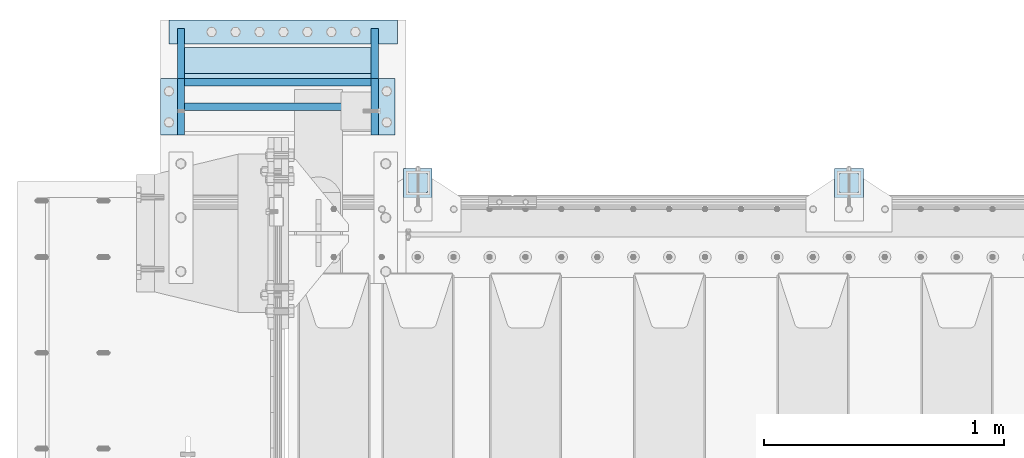
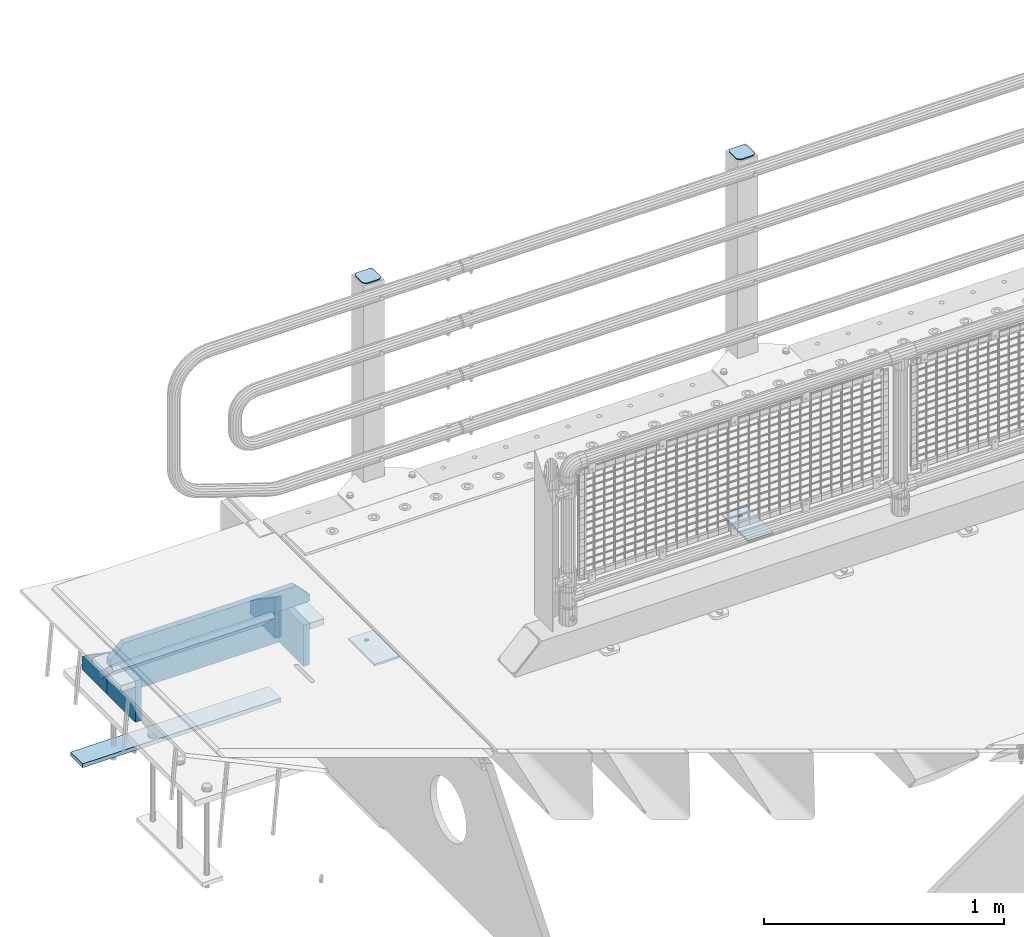
# One storey, part 214 of 247: 14 plates.
"""IFC2X3 building model written with IfcOpenShell, lengths in millimetres."""

from ifc_helpers import new_model, si_unit, frame, origin_with_axes, place, context, subcontext, project, spatial, faceted_brep, material, type_object, element, save


model = new_model("IFC2X3")

# Units and contexts
model_context = context("Model", 3, precision=1e-05, world=origin_with_axes())
body_context = subcontext(model_context, "Body", "Model", "MODEL_VIEW")
ifc_project = project(units=[si_unit("LENGTHUNIT", "METRE", prefix="MILLI"), si_unit("AREAUNIT", "SQUARE_METRE"), si_unit("VOLUMEUNIT", "CUBIC_METRE"), si_unit("MASSUNIT", "GRAM", prefix="KILO"), si_unit("TIMEUNIT", "SECOND"), si_unit("PLANEANGLEUNIT", "RADIAN"), si_unit("SOLIDANGLEUNIT", "STERADIAN"), si_unit("THERMODYNAMICTEMPERATUREUNIT", "DEGREE_CELSIUS"), si_unit("LUMINOUSINTENSITYUNIT", "LUMEN")], contexts=[model_context])

# Site, building, storey
site_placement = place(None, origin_with_axes())
site = spatial("IfcSite", under=ifc_project, at=site_placement, CompositionType="ELEMENT")
building_placement = place(site_placement, origin_with_axes())
building = spatial("IfcBuilding", under=site, at=building_placement, Name="Standard", CompositionType="ELEMENT")
storey_placement = place(building_placement, origin_with_axes())
storey = spatial("IfcBuildingStorey", under=building, at=storey_placement, Name="Undefined", CompositionType="ELEMENT", Elevation=0.0)

# Plates
ifc_material_1 = material(Name="STEEL/S355N")
plate_type_1 = type_object("IfcPlateType", PredefinedType="NOTDEFINED")
plate_1_placement = place(storey_placement, frame((354.999999574466, 9765.35713634785, -1017.14966545659), z_axis=(-1.0, 0.0, 0.0), x_axis=(9.99999918650255e-10, -0.723355636225728, 0.690475650215467)))
element("IfcPlate", 1, at=plate_1_placement, inside=storey, type_object=plate_type_1, material=ifc_material_1, context=body_context, shape_type="Brep", body=[
    faceted_brep([(0.0, -15.0, 0.0), (2.15506588574499e-07, -15.0, 779.0), (2.15505679079797e-07, 15.0000000000009, 779.0), (0.0, 15.0, 0.0), (152.069061494803, -14.9999999999991, 779.0), (152.069061494803, 15.0000000000009, 779.0), (152.069061279297, -14.9999999999991, 0.0), (152.069061279298, 15.0000000000009, 5.6843418860808e-14)], [[[0, 1, 2, 3]], [[1, 4, 5, 2]], [[4, 6, 7, 5]], [[6, 0, 3, 7]], [[5, 7, 3, 2]], [[6, 4, 1, 0]]]),
])
plate_type_2 = type_object("IfcPlateType", PredefinedType="NOTDEFINED")
plate_2_placement = place(storey_placement, frame((-489.000000550232, 9889.99999928438, -1468.0), z_axis=(0.0, -0.999999999999548, -9.5100000000016e-07), x_axis=(1.0, 0.0, 0.0)))
element("IfcPlate", 2, at=plate_2_placement, inside=storey, type_object=plate_type_2, material=ifc_material_1, context=body_context, shape_type="Brep", body=[
    faceted_brep([(-5.6843418860808e-14, -9.99999999999989, 3.5527136788005e-15), (0.0, -10.0, 100.0), (0.0, 10.0, 100.0), (-5.6843418860808e-14, 10.0000000000001, 3.5527136788005e-15), (955.0, -10.0, 100.0), (955.0, 10.0, 100.0), (955.0, -10.0, 0.0), (955.0, 10.0, 0.0)], [[[0, 1, 2, 3]], [[1, 4, 5, 2]], [[4, 6, 7, 5]], [[6, 0, 3, 7]], [[5, 7, 3, 2]], [[6, 4, 1, 0]]]),
])
plate_type_3 = type_object("IfcPlateType", PredefinedType="NOTDEFINED")
for number, where, z_axis, x_axis in (
    (3, (369.999999484786, 9855.00000160961, -1028.0), (0.0, 0.0, 1.0), (0.0, -0.999999999999548, -9.5100000000016e-07)),
    (4, (-439.000000515218, 9855.00000080062, -1028.0), (0.0, 0.0, 1.0), (0.0, -0.999999999999548, -9.5100000000016e-07)),
):
    element("IfcPlate", number, at=place(storey_placement, frame(where, z_axis=z_axis, x_axis=x_axis)), inside=storey, type_object=plate_type_3, material=ifc_material_1, context=body_context, shape_type="Brep", body=[
        faceted_brep([(0.0, -15.0, 0.0), (-1.81898940354586e-12, -15.0, 66.0), (0.0, 15.0, 66.0), (0.0, 15.0, 0.0), (209.999999999998, -15.0, 210.0), (210.0, 15.0, 210.0), (209.999999999998, -15.0, 0.0), (210.0, 15.0, 0.0)], [[[0, 1, 2, 3]], [[1, 4, 5, 2]], [[4, 6, 7, 5]], [[6, 0, 3, 7]], [[5, 7, 3, 2]], [[6, 4, 1, 0]]]),
    ])
plate_3_placement = place(storey_placement, frame((369.999999929983, 9410.00000160961, -818.000000000005), z_axis=(0.0, 0.0, -1.0), x_axis=(0.0, 1.0, 0.0)))
element("IfcPlate", 5, at=plate_3_placement, inside=storey, type_object=plate_type_3, material=ifc_material_1, context=body_context, shape_type="Brep", body=[
    faceted_brep([(0.0, -15.0, 0.0), (1.81898940354586e-12, -15.0, 210.0), (0.0, 15.0, 210.0), (0.0, 15.0, 0.0), (235.000000000002, -15.0, 210.0), (235.0, 15.0, 210.0), (235.0, -15.0, 0.0), (235.0, 15.0, 0.0)], [[[0, 1, 2, 3]], [[1, 4, 5, 2]], [[4, 6, 7, 5]], [[6, 0, 3, 7]], [[5, 7, 3, 2]], [[6, 4, 1, 0]]]),
])
plate_4_placement = place(storey_placement, frame((-424.000000290114, 9630.00000081562, -1028.0), z_axis=(1.0, 0.0, 0.0), x_axis=(0.0, 0.0, 1.0)))
element("IfcPlate", 6, at=plate_4_placement, inside=storey, type_object=plate_type_3, material=ifc_material_1, context=body_context, shape_type="Brep", body=[
    faceted_brep([(0.0, -15.0, 0.0), (2.15506588574499e-07, -15.0, 779.0), (2.15505679079797e-07, 15.0000000000009, 779.0), (0.0, 15.0, 0.0), (210.0, -15.0, 779.0), (210.0, 15.0, 779.0), (209.999999999998, -15.0, 0.0), (210.0, 15.0, 0.0)], [[[0, 1, 2, 3]], [[1, 4, 5, 2]], [[4, 6, 7, 5]], [[6, 0, 3, 7]], [[5, 7, 3, 2]], [[6, 4, 1, 0]]]),
])
plate_5_placement = place(storey_placement, frame((-439.000000070017, 9410.00000080062, -818.000000000004), z_axis=(0.0, 0.0, -1.0), x_axis=(0.0, 1.0, 0.0)))
element("IfcPlate", 7, at=plate_5_placement, inside=storey, type_object=plate_type_3, material=ifc_material_1, context=body_context, shape_type="Brep", body=[
    faceted_brep([(0.0, -15.0, 0.0), (1.81898940354586e-12, -15.0, 210.0), (0.0, 15.0, 210.0), (0.0, 15.0, 0.0), (235.000000000002, -15.0, 210.0), (235.0, 15.0, 210.0), (235.0, -15.0, 0.0), (235.0, 15.0, 0.0)], [[[0, 1, 2, 3]], [[1, 4, 5, 2]], [[4, 6, 7, 5]], [[6, 0, 3, 7]], [[5, 7, 3, 2]], [[6, 4, 1, 0]]]),
])
plate_type_4 = type_object("IfcPlateType", PredefinedType="NOTDEFINED")
plate_6_placement = place(storey_placement, frame((-514.000000187569, 9527.50000072562, -788.000000000004), z_axis=(0.0, 0.0, 1.0), x_axis=(1.0, 0.0, 0.0)))
element("IfcPlate", 8, at=plate_6_placement, inside=storey, type_object=plate_type_4, material=ifc_material_1, context=body_context, shape_type="Brep", body=[
    faceted_brep([(0.0, -15.0, 0.0), (0.0, -15.0, 33.0), (0.0, 15.0, 33.0), (0.0, 15.0, 0.0), (67.0, -15.0, 100.0), (67.0, 15.0, 100.0), (892.0, -15.0000000000018, 100.0), (892.0, 14.9999999999982, 100.0), (959.0, -15.0, 33.0), (959.0, 15.0, 33.0), (959.0, -15.0, 0.0), (959.0, 15.0, 0.0)], [[[0, 1, 2, 3]], [[1, 4, 5, 2]], [[4, 6, 7, 5]], [[6, 8, 9, 7]], [[8, 10, 11, 9]], [[10, 0, 3, 11]], [[5, 7, 9, 11, 3, 2]], [[10, 8, 6, 4, 1, 0]]]),
])
plate_type_5 = type_object("IfcPlateType", PredefinedType="NOTDEFINED")
for number, where, z_axis, x_axis in (
    (9, (384.999999694879, 9645.00000162461, -833.000000000004), (1.0, 0.0, 0.0), (0.0, -0.999999999999548, -9.5100000000016e-07)),
    (10, (-524.000000305121, 9645.00000071562, -833.000000000004), (1.0, 0.0, 0.0), (0.0, -0.999999999999548, -9.5100000000016e-07)),
):
    element("IfcPlate", number, at=place(storey_placement, frame(where, z_axis=z_axis, x_axis=x_axis)), inside=storey, type_object=plate_type_5, material=ifc_material_1, context=body_context, shape_type="Brep", body=[
        faceted_brep([(0.0, -15.0, 0.0), (0.0, -15.0, 70.0), (0.0, 15.0, 70.0), (0.0, 15.0, 0.0), (235.0, -15.0, 70.0), (235.0, 15.0, 70.0), (235.0, -15.0, 0.0), (235.0, 15.0, 0.0)], [[[0, 1, 2, 3]], [[1, 4, 5, 2]], [[4, 6, 7, 5]], [[6, 0, 3, 7]], [[5, 7, 3, 2]], [[6, 4, 1, 0]]]),
    ])
ifc_material_2 = material(Name="STEEL/S355J2")
plate_type_6 = type_object("IfcPlateType", PredefinedType="NOTDEFINED")
for number, where, z_axis, x_axis in (
    (11, (2290.00000000014, 9050.00000000021, -850.000000000002), (0.0, 1.0, 0.0), (1.0, 0.0, 0.0)),
    (12, (490.000000000138, 9050.00000000021, -850.000000000002), (0.0, 1.0, 0.0), (1.0, 0.0, 0.0)),
):
    element("IfcPlate", number, at=place(storey_placement, frame(where, z_axis=z_axis, x_axis=x_axis)), inside=storey, type_object=plate_type_6, material=ifc_material_2, context=body_context, shape_type="Brep", body=[
        faceted_brep([(66.3639610305399, -5.0, 163.636038969113), (66.3639610305399, 5.0, 163.636038969113), (59.9999999998618, 5.0, 160.999999999791), (59.9999999998618, -5.0, 160.999999999791), (53.6360389691836, 5.0, 163.636038969113), (53.6360389691836, -5.0, 163.636038969113), (50.9999999998618, 5.0, 169.999999999791), (50.9999999998618, -5.0, 169.999999999791), (53.6360389691836, 5.0, 176.363961030469), (53.6360389691836, -5.0, 176.363961030469), (59.9999999998618, 5.0, 178.999999999791), (59.9999999998618, -5.0, 178.999999999791), (66.3639610305399, 5.0, 176.363961030469), (66.3639610305399, -5.0, 176.363961030469), (68.9999999998618, 5.0, 169.999999999791), (68.9999999998618, -5.0, 169.999999999791), (120.0, -5.0, 0.0), (120.0, -5.0, 220.0), (0.0, -5.0, 220.0), (9.04219632502645e-09, -5.00000000143385, -2.89173840428703e-09), (7.66340235713869e-09, 4.99999999856618, -2.89173840428703e-09), (120.0, 5.0, 0.0), (120.0, 5.0, 220.0), (0.0, 5.0, 220.0)], [[[0, 1, 2, 3]], [[3, 2, 4, 5]], [[5, 4, 6, 7]], [[7, 6, 8, 9]], [[9, 8, 10, 11]], [[11, 10, 12, 13]], [[13, 12, 14, 15]], [[15, 14, 1, 0]], [[16, 17, 18, 19], [3, 5, 7, 9, 11, 13, 15, 0]], [[16, 19, 20, 21]], [[17, 16, 21, 22]], [[18, 17, 22, 23]], [[19, 18, 23, 20]], [[22, 21, 20, 23], [10, 8, 6, 4, 2, 1, 14, 12]]]),
    ])
plate_type_7 = type_object("IfcPlateType", PredefinedType="NOTDEFINED")
plate_7_placement = place(storey_placement, frame((2394.00000000013, 9166.00000000021, 1012.50000000001), z_axis=(0.0, 1.0, 0.0), x_axis=(-1.0, 0.0, 0.0)))
element("IfcPlate", 13, at=plate_7_placement, inside=storey, type_object=plate_type_7, material=ifc_material_2, context=body_context, shape_type="Brep", body=[
    faceted_brep([(0.0, -2.5, 19.0), (0.0, -2.5, 69.0), (0.0, 2.5, 69.0), (0.0, 2.5, 19.0), (0.476369668545885, -2.5, 73.2278977451697), (0.476369668545885, 2.5, 73.2278977451697), (1.88159150985484, -2.5, 77.2437910432327), (1.88159150985484, 2.5, 77.2437910432327), (4.14520183310742, -2.5, 80.8463062353167), (4.14520183310742, 2.5, 80.8463062353167), (7.15369376468334, -2.5, 83.8547981668926), (7.15369376468334, 2.5, 83.8547981668926), (10.7562089567673, -2.5, 86.1184084901452), (10.7562089567673, 2.5, 86.1184084901452), (14.7721022548303, -2.5, 87.5236303314541), (14.7721022548303, 2.5, 87.5236303314541), (19.0, -2.5, 88.0), (19.0, 2.5, 88.0), (69.0, -2.5, 88.0), (69.0, 2.5, 88.0), (73.2278977451697, -2.5, 87.5236303314541), (73.2278977451697, 2.5, 87.5236303314541), (77.2437910432327, -2.5, 86.1184084901452), (77.2437910432327, 2.5, 86.1184084901452), (80.8463062353167, -2.5, 83.8547981668926), (80.8463062353167, 2.5, 83.8547981668926), (83.8547981668926, -2.5, 80.8463062353167), (83.8547981668926, 2.5, 80.8463062353167), (86.1184084901452, -2.5, 77.2437910432327), (86.1184084901452, 2.5, 77.2437910432327), (87.5236303314541, -2.5, 73.2278977451697), (87.5236303314541, 2.5, 73.2278977451697), (88.0, -2.5, 69.0), (88.0, 2.5, 69.0), (88.0, -2.5, 19.0), (88.0, 2.5, 19.0), (87.5236303314541, -2.5, 14.7721022548303), (87.5236303314541, 2.5, 14.7721022548303), (86.1184084901452, -2.5, 10.7562089567673), (86.1184084901452, 2.5, 10.7562089567673), (83.8547981668926, -2.5, 7.15369376468334), (83.8547981668926, 2.5, 7.15369376468334), (80.8463062353167, -2.5, 4.14520183310742), (80.8463062353167, 2.5, 4.14520183310742), (77.2437910432345, -2.5, 1.88159150985484), (77.2437910432345, 2.5, 1.88159150985484), (73.2278977451697, -2.5, 0.476369668545885), (73.2278977451697, 2.5, 0.476369668545885), (69.0, -2.5, 0.0), (69.0, 2.5, 0.0), (19.0, -2.5, 0.0), (19.0, 2.5, 0.0), (14.7721022548303, -2.5, 0.476369668545885), (14.7721022548303, 2.5, 0.476369668545885), (10.7562089567673, -2.5, 1.88159150985484), (10.7562089567673, 2.5, 1.88159150985484), (7.15369376468334, -2.5, 4.14520183310742), (7.15369376468334, 2.5, 4.14520183310742), (4.14520183310742, -2.5, 7.15369376468334), (4.14520183310742, 2.5, 7.15369376468334), (1.88159150985484, -2.5, 10.7562089567673), (1.88159150985484, 2.5, 10.7562089567673), (0.476369668545885, -2.5, 14.7721022548303), (0.476369668545885, 2.5, 14.7721022548303)], [[[0, 1, 2, 3]], [[1, 4, 5, 2]], [[4, 6, 7, 5]], [[6, 8, 9, 7]], [[8, 10, 11, 9]], [[10, 12, 13, 11]], [[12, 14, 15, 13]], [[14, 16, 17, 15]], [[16, 18, 19, 17]], [[18, 20, 21, 19]], [[20, 22, 23, 21]], [[22, 24, 25, 23]], [[24, 26, 27, 25]], [[26, 28, 29, 27]], [[28, 30, 31, 29]], [[30, 32, 33, 31]], [[32, 34, 35, 33]], [[34, 36, 37, 35]], [[36, 38, 39, 37]], [[38, 40, 41, 39]], [[40, 42, 43, 41]], [[42, 44, 45, 43]], [[44, 46, 47, 45]], [[46, 48, 49, 47]], [[48, 50, 51, 49]], [[50, 52, 53, 51]], [[52, 54, 55, 53]], [[54, 56, 57, 55]], [[56, 58, 59, 57]], [[58, 60, 61, 59]], [[60, 62, 63, 61]], [[62, 0, 3, 63]], [[5, 7, 9, 11, 13, 15, 17, 19, 21, 23, 25, 27, 29, 31, 33, 35, 37, 39, 41, 43, 45, 47, 49, 51, 53, 55, 57, 59, 61, 63, 3, 2]], [[62, 60, 58, 56, 54, 52, 50, 48, 46, 44, 42, 40, 38, 36, 34, 32, 30, 28, 26, 24, 22, 20, 18, 16, 14, 12, 10, 8, 6, 4, 1, 0]]]),
])
plate_8_placement = place(storey_placement, frame((594.000000000131, 9166.00000000021, 1012.50000000001), z_axis=(0.0, 1.0, 0.0), x_axis=(-1.0, 0.0, 0.0)))
element("IfcPlate", 14, at=plate_8_placement, inside=storey, type_object=plate_type_7, material=ifc_material_2, context=body_context, shape_type="Brep", body=[
    faceted_brep([(0.0, -2.5, 19.0), (0.0, -2.5, 69.0), (0.0, 2.5, 69.0), (0.0, 2.5, 19.0), (0.476369668545885, -2.5, 73.2278977451697), (0.476369668545885, 2.5, 73.2278977451697), (1.88159150985484, -2.5, 77.2437910432327), (1.88159150985484, 2.5, 77.2437910432327), (4.14520183310742, -2.5, 80.8463062353167), (4.14520183310742, 2.5, 80.8463062353167), (7.15369376468334, -2.5, 83.8547981668926), (7.15369376468334, 2.5, 83.8547981668926), (10.7562089567673, -2.5, 86.1184084901452), (10.7562089567673, 2.5, 86.1184084901452), (14.7721022548303, -2.5, 87.5236303314541), (14.7721022548303, 2.5, 87.5236303314541), (19.0, -2.5, 88.0), (19.0, 2.5, 88.0), (69.0, -2.5, 88.0), (69.0, 2.5, 88.0), (73.2278977451697, -2.5, 87.5236303314541), (73.2278977451697, 2.5, 87.5236303314541), (77.2437910432327, -2.5, 86.1184084901452), (77.2437910432327, 2.5, 86.1184084901452), (80.8463062353167, -2.5, 83.8547981668926), (80.8463062353167, 2.5, 83.8547981668926), (83.8547981668926, -2.5, 80.8463062353167), (83.8547981668926, 2.5, 80.8463062353167), (86.1184084901452, -2.5, 77.2437910432327), (86.1184084901452, 2.5, 77.2437910432327), (87.5236303314541, -2.5, 73.2278977451697), (87.5236303314541, 2.5, 73.2278977451697), (88.0, -2.5, 69.0), (88.0, 2.5, 69.0), (88.0, -2.5, 19.0), (88.0, 2.5, 19.0), (87.5236303314541, -2.5, 14.7721022548303), (87.5236303314541, 2.5, 14.7721022548303), (86.1184084901452, -2.5, 10.7562089567673), (86.1184084901452, 2.5, 10.7562089567673), (83.8547981668926, -2.5, 7.15369376468334), (83.8547981668926, 2.5, 7.15369376468334), (80.8463062353167, -2.5, 4.14520183310742), (80.8463062353167, 2.5, 4.14520183310742), (77.2437910432345, -2.5, 1.88159150985484), (77.2437910432345, 2.5, 1.88159150985484), (73.2278977451697, -2.5, 0.476369668545885), (73.2278977451697, 2.5, 0.476369668545885), (69.0, -2.5, 0.0), (69.0, 2.5, 0.0), (19.0, -2.5, 0.0), (19.0, 2.5, 0.0), (14.7721022548303, -2.5, 0.476369668545885), (14.7721022548303, 2.5, 0.476369668545885), (10.7562089567673, -2.5, 1.88159150985484), (10.7562089567673, 2.5, 1.88159150985484), (7.15369376468334, -2.5, 4.14520183310742), (7.15369376468334, 2.5, 4.14520183310742), (4.14520183310742, -2.5, 7.15369376468334), (4.14520183310742, 2.5, 7.15369376468334), (1.88159150985484, -2.5, 10.7562089567673), (1.88159150985484, 2.5, 10.7562089567673), (0.476369668545885, -2.5, 14.7721022548303), (0.476369668545885, 2.5, 14.7721022548303)], [[[0, 1, 2, 3]], [[1, 4, 5, 2]], [[4, 6, 7, 5]], [[6, 8, 9, 7]], [[8, 10, 11, 9]], [[10, 12, 13, 11]], [[12, 14, 15, 13]], [[14, 16, 17, 15]], [[16, 18, 19, 17]], [[18, 20, 21, 19]], [[20, 22, 23, 21]], [[22, 24, 25, 23]], [[24, 26, 27, 25]], [[26, 28, 29, 27]], [[28, 30, 31, 29]], [[30, 32, 33, 31]], [[32, 34, 35, 33]], [[34, 36, 37, 35]], [[36, 38, 39, 37]], [[38, 40, 41, 39]], [[40, 42, 43, 41]], [[42, 44, 45, 43]], [[44, 46, 47, 45]], [[46, 48, 49, 47]], [[48, 50, 51, 49]], [[50, 52, 53, 51]], [[52, 54, 55, 53]], [[54, 56, 57, 55]], [[56, 58, 59, 57]], [[58, 60, 61, 59]], [[60, 62, 63, 61]], [[62, 0, 3, 63]], [[5, 7, 9, 11, 13, 15, 17, 19, 21, 23, 25, 27, 29, 31, 33, 35, 37, 39, 41, 43, 45, 47, 49, 51, 53, 55, 57, 59, 61, 63, 3, 2]], [[62, 60, 58, 56, 54, 52, 50, 48, 46, 44, 42, 40, 38, 36, 34, 32, 30, 28, 26, 24, 22, 20, 18, 16, 14, 12, 10, 8, 6, 4, 1, 0]]]),
])

save(model, "model.ifc")
